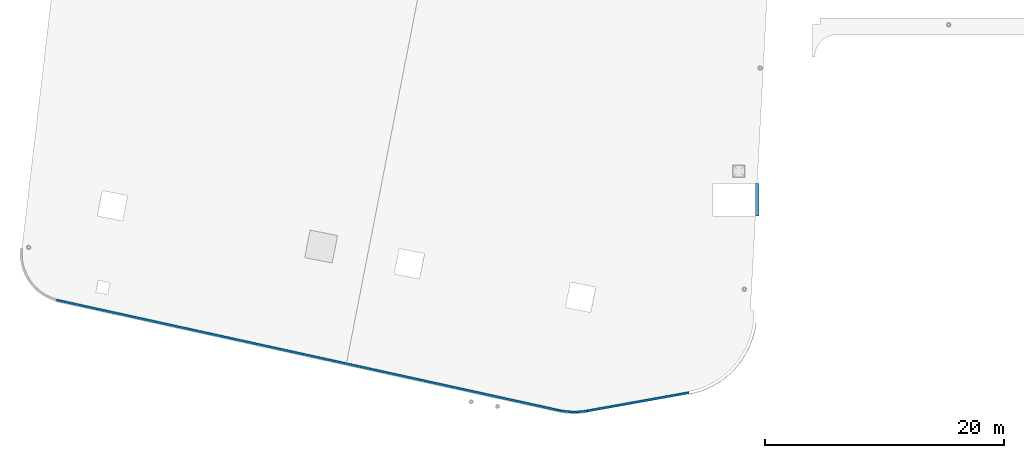
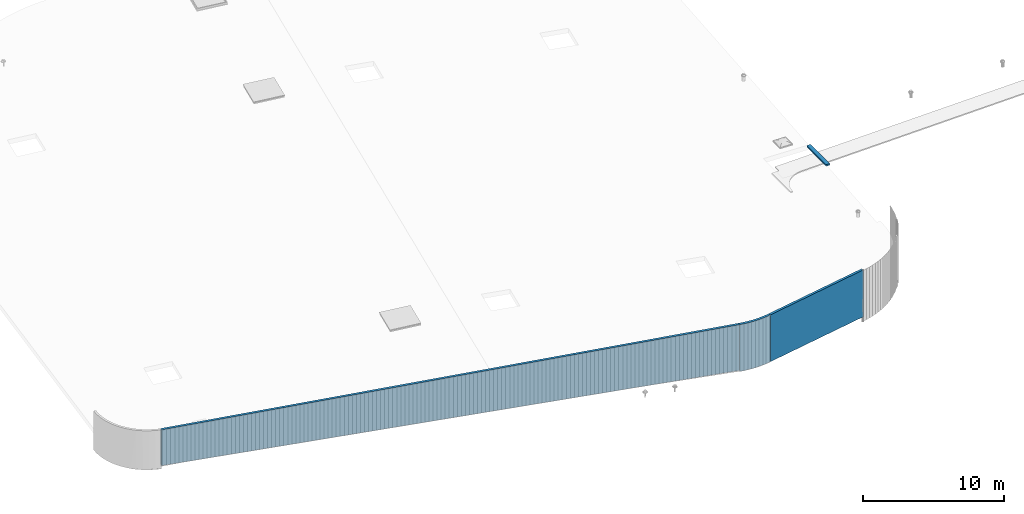
# One storey, part 8 of 18: 4 walls.
"""IFC2X3 building model written with IfcOpenShell, lengths in centimetres."""

from ifc_helpers import new_model, entity, si_unit, converted_unit, derived_unit, direction, frame, frame_2d, origin, place, context, subcontext, project, spatial, polyline, circle_curve, parameter, trimmed, segment, composite_curve, rectangle, outline, extrude, clip, halfspace, bounded_halfspace, material, layer, layer_set, layer_usage, type_object, element, save


model = new_model("IFC2X3")

# Units and contexts
model_context = context("Model", 3, precision=0.001, world=origin(), true_north=direction((6.12303176911189e-17, 1.0)))
body_context = subcontext(model_context, "Body", "Model", "MODEL_VIEW")
ifc_project = project(units=[si_unit("LENGTHUNIT", "METRE", prefix="CENTI"), si_unit("AREAUNIT", "SQUARE_METRE"), si_unit("VOLUMEUNIT", "CUBIC_METRE"), converted_unit("PLANEANGLEUNIT", "DEGREE", entity("IfcRatioMeasure", 0.0174532925199433), si_unit("PLANEANGLEUNIT", "RADIAN"), dimensions=[0, 0, 0, 0, 0, 0, 0]), si_unit("MASSUNIT", "GRAM", prefix="KILO"), derived_unit("MASSDENSITYUNIT", [(si_unit("MASSUNIT", "GRAM", prefix="KILO"), 1), (si_unit("LENGTHUNIT", "METRE"), -3)]), si_unit("TIMEUNIT", "SECOND"), si_unit("FREQUENCYUNIT", "HERTZ"), si_unit("THERMODYNAMICTEMPERATUREUNIT", "DEGREE_CELSIUS"), derived_unit("THERMALTRANSMITTANCEUNIT", [(si_unit("MASSUNIT", "GRAM", prefix="KILO"), 1), (si_unit("THERMODYNAMICTEMPERATUREUNIT", "KELVIN"), -1), (si_unit("TIMEUNIT", "SECOND"), -3)]), derived_unit("VOLUMETRICFLOWRATEUNIT", [(si_unit("LENGTHUNIT", "METRE"), 3), (si_unit("TIMEUNIT", "SECOND"), -1)]), si_unit("ELECTRICCURRENTUNIT", "AMPERE"), si_unit("ELECTRICVOLTAGEUNIT", "VOLT"), si_unit("POWERUNIT", "WATT"), si_unit("FORCEUNIT", "NEWTON", prefix="KILO"), si_unit("ILLUMINANCEUNIT", "LUX"), si_unit("LUMINOUSFLUXUNIT", "LUMEN"), si_unit("LUMINOUSINTENSITYUNIT", "CANDELA"), derived_unit("USERDEFINED", [(si_unit("MASSUNIT", "GRAM", prefix="KILO"), -1), (si_unit("LENGTHUNIT", "METRE"), -2), (si_unit("TIMEUNIT", "SECOND"), 3), (si_unit("LUMINOUSFLUXUNIT", "LUMEN"), 1)]), derived_unit("LINEARVELOCITYUNIT", [(si_unit("LENGTHUNIT", "METRE"), 1), (si_unit("TIMEUNIT", "SECOND"), -1)]), si_unit("PRESSUREUNIT", "PASCAL"), derived_unit("USERDEFINED", [(si_unit("LENGTHUNIT", "METRE"), -2), (si_unit("MASSUNIT", "GRAM", prefix="KILO"), 1), (si_unit("TIMEUNIT", "SECOND"), -2)])], contexts=[model_context])

# Site, building, storey
site_placement = place(None, origin())
site = spatial("IfcSite", under=ifc_project, at=site_placement, CompositionType="ELEMENT")
building_placement = place(site_placement, origin())
building = spatial("IfcBuilding", under=site, at=building_placement, CompositionType="ELEMENT")
storey_placement = place(building_placement, frame((0.0, 0.0, 1422.0)))
storey = spatial("IfcBuildingStorey", under=building, at=storey_placement, CompositionType="ELEMENT", Elevation=1422.0)

# Walls
ifc_material_1 = material()
ifc_layer_1 = layer(ifc_material_1, 30.0)
ifc_layer_set_1 = layer_set([ifc_layer_1])
ifc_layer_usage_1 = layer_usage(ifc_layer_set_1, "AXIS2", "NEGATIVE", 15.0)
wall_type_1 = type_object("IfcWallType", PredefinedType="STANDARD", material=ifc_layer_set_1)
wall_1_placement = place(storey_placement, frame((9922.40804826818, 2066.49388271673, -200.0), z_axis=(0.0, 0.0, 1.0), x_axis=(0.0, -1.0, 0.0)))
element("IfcWallStandardCase", 1, at=wall_1_placement, inside=storey, type_object=wall_type_1, material=ifc_layer_usage_1, context=body_context, shape_type="Clipping", body=[
    clip(extrude(rectangle(XDim=274.0, YDim=30.0000000000001, at=frame_2d((137.0, 1.56319401867222e-13), x_axis=(-1.0, 0.0))), origin(), (0.0, 0.0, 1.0), 15.0000000000001), bounded_halfspace(frame((3.84474139991653e-08, -15.0, 15.0), z_axis=(0.0, 0.0, -1.0), x_axis=(0.0, -1.0, 0.0)), True, frame((3.84474139991653e-08, -15.0, 15.0)), polyline([(0.0, 0.0), (23.0, 0.0), (274.0, 0.0), (274.0, 1.72823730919785), (-3.84474105885602e-08, 16.2759505085688), (0.0, 0.0)]))),
])
ifc_material_2 = material(Name="Isolation")
ifc_layer_2 = layer(ifc_material_2, 10.0)
ifc_layer_3 = layer(ifc_material_2, 9.0)
ifc_material_3 = material(Name="Acier")
ifc_layer_4 = layer(ifc_material_3, 1.0)
ifc_layer_set_2 = layer_set([ifc_layer_2, ifc_layer_3, ifc_layer_4])
ifc_layer_usage_2 = layer_usage(ifc_layer_set_2, "AXIS2", "NEGATIVE", 10.0)
wall_type_2 = type_object("IfcWallType", PredefinedType="NOTDEFINED", material=ifc_layer_set_2)
wall_2_placement = place(storey_placement, frame((8259.97467993293, 169.112129684276, -395.595487226715), z_axis=(0.0, 0.0, 1.0), x_axis=(-0.976731958442774, 0.214463706385354, 0.0)))
element("IfcWallStandardCase", 2, at=wall_2_placement, inside=storey, type_object=wall_type_2, material=ifc_layer_usage_2, context=body_context, shape_type="Clipping", body=[
    clip(extrude(rectangle(XDim=4298.18269874461, YDim=19.9999999999999, at=frame_2d((2149.0913493723, 2.39808173319034e-14), x_axis=(-1.0, 0.0))), origin(), (0.0, 0.0, 1.0), 395.595487226715), halfspace(frame((4298.1826987446, -10.0, 86.5451013817512), z_axis=(0.0201311970232418, 0.0, -0.99979734691907), x_axis=(0.0, 1.0, 0.0)), False)),
])
ifc_layer_usage_3 = layer_usage(ifc_layer_set_2, "AXIS2", "NEGATIVE", 10.0)
wall_3_placement = place(storey_placement, frame((9353.13855499899, 316.420931316361, -405.231125928375), z_axis=(0.0, 0.0, 1.0), x_axis=(-0.984318341919638, -0.17640125215138, 0.0)))
element("IfcWallStandardCase", 3, at=wall_3_placement, inside=storey, type_object=wall_type_2, material=ifc_layer_usage_3, context=body_context, shape_type="SweptSolid", body=[
    extrude(rectangle(XDim=861.999999999999, YDim=19.9999999999999, at=frame_2d((431.0, 8.88178419700125e-14), x_axis=(-1.0, 0.0))), origin(), (0.0, 0.0, 1.0), 405.231125928375),
])
ifc_layer_usage_4 = layer_usage(ifc_layer_set_2, "AXIS2", "POSITIVE", -10.0)
wall_4_placement = place(storey_placement, frame((8259.97467992676, 169.11212965617, -405.0)))
element("IfcWallStandardCase", 4, at=wall_4_placement, inside=storey, type_object=wall_type_2, material=ifc_layer_usage_4, context=body_context, shape_type="SweptSolid", body=[
    extrude(outline(composite_curve([segment(trimmed(circle_curve(frame_2d((134.254280197241, 611.434205985174), x_axis=(1.0, 0.0)), 616.0), [parameter(257.615933951638)], [parameter(280.160212640796)], True, "PARAMETER"), False, "CONTINUOUS"), segment(polyline([(2.14463706385672, 9.76731958442689), (-2.14463706385326, -9.76731958442775)]), True, "CONTINUOUS"), segment(trimmed(circle_curve(frame_2d((134.254280197241, 611.434205985174), x_axis=(1.0, 0.0)), 636.0), [parameter(257.615933951638)], [parameter(280.160212640796)], True, "PARAMETER"), True, "CONTINUOUS"), segment(polyline([(246.445476565515, -14.5922594757162), (242.917451522491, 5.09410736267725)]), True, "CONTINUOUS")], self_intersect=False)), origin(), (0.0, 0.0, 1.0), 405.0),
])

save(model, "model.ifc")
